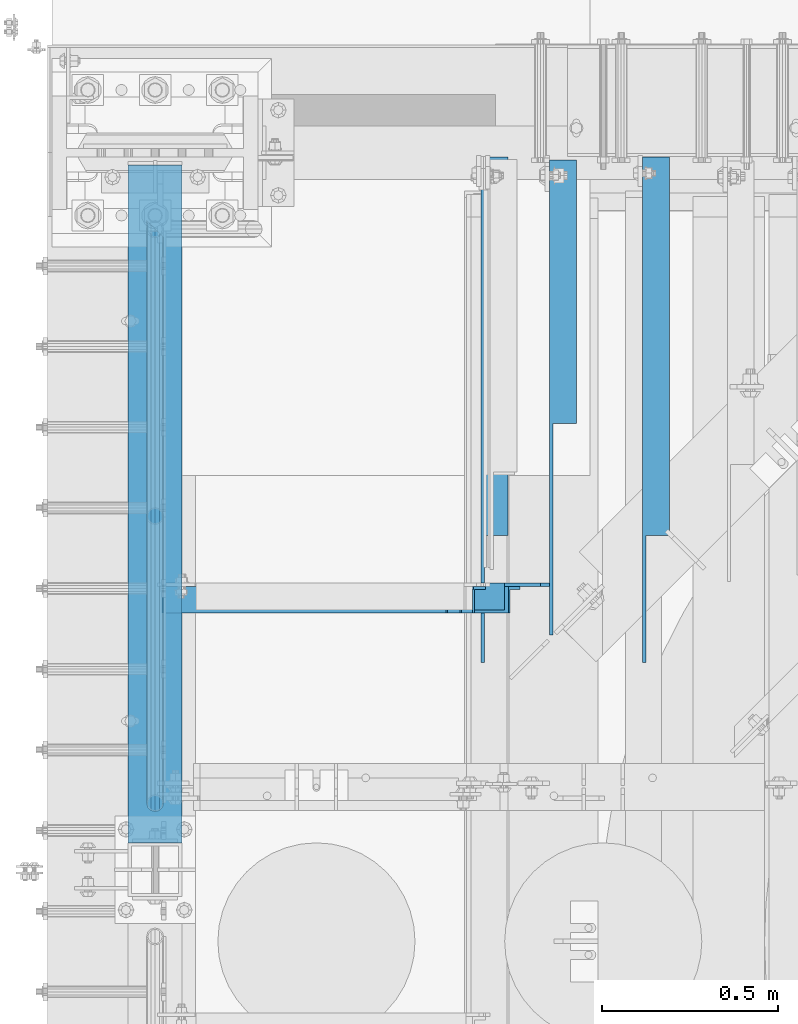
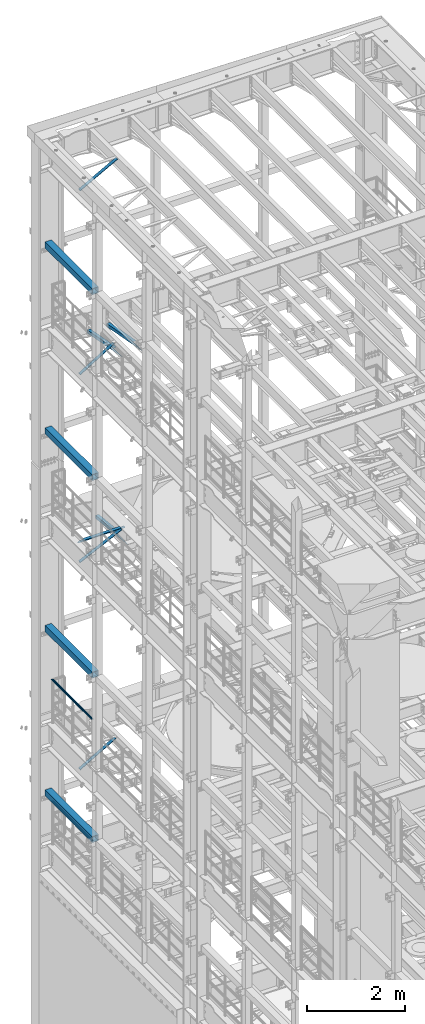
# One storey, part 1053 of 1876: 10 beams, 4 members, 14 elements without a shape of their own.
"""IFC2X3 building model written with IfcOpenShell, lengths in millimetres."""

from ifc_helpers import new_model, si_unit, frame, origin_with_axes, place, context, subcontext, project, spatial, faceted_brep, material, type_object, element, aggregate, save


model = new_model("IFC2X3")

# Units and contexts
model_context = context("Model", 3, precision=1e-05, world=origin_with_axes())
body_context = subcontext(model_context, "Body", "Model", "MODEL_VIEW")
ifc_project = project(units=[si_unit("LENGTHUNIT", "METRE", prefix="MILLI"), si_unit("AREAUNIT", "SQUARE_METRE"), si_unit("VOLUMEUNIT", "CUBIC_METRE"), si_unit("MASSUNIT", "GRAM", prefix="KILO"), si_unit("TIMEUNIT", "SECOND"), si_unit("PLANEANGLEUNIT", "RADIAN"), si_unit("SOLIDANGLEUNIT", "STERADIAN"), si_unit("THERMODYNAMICTEMPERATUREUNIT", "DEGREE_CELSIUS"), si_unit("LUMINOUSINTENSITYUNIT", "LUMEN")], contexts=[model_context])

# Site, building, storey
site_placement = place(None, origin_with_axes())
site = spatial("IfcSite", under=ifc_project, at=site_placement, CompositionType="ELEMENT")
building_placement = place(site_placement, origin_with_axes())
building = spatial("IfcBuilding", under=site, at=building_placement, Name="Undefined", CompositionType="ELEMENT")
storey_placement = place(building_placement, origin_with_axes())
storey = spatial("IfcBuildingStorey", under=building, at=storey_placement, Name="Undefined", CompositionType="ELEMENT", Elevation=0.0)

# Assembly, beam
assembly_1_placement = place(storey_placement, origin_with_axes())
assembly_1 = element("IfcElementAssembly", 1, at=assembly_1_placement, inside=storey, Name="RAIL", AssemblyPlace="NOTDEFINED", PredefinedType="RIGID_FRAME")
ifc_material_1 = material()
beam_type_1 = type_object("IfcBeamType", Name="PIPE1-1/2SCH40", PredefinedType="NOTDEFINED")
beam_1_placement = place(assembly_1_placement, frame((-2.72848410531878e-11, 11848.7825, 9229.725), z_axis=(0.0, 0.0, -1.0), x_axis=(0.0, 1.0, 0.0)))
beam_1 = element("IfcBeam", 2, at=beam_1_placement, type_object=beam_type_1, material=ifc_material_1, Name="RAIL", ObjectType="PIPE1-1/2SCH40", context=body_context, shape_type="Brep", body=[
    faceted_brep([(24.1300000000001, -20.4469999999999, 0.0), (34.3535000000002, -17.7076214311803, 10.2235000000001), (1668.63142143118, -17.7076214311804, 10.2235000000001), (1671.3708, -20.447, 0.0), (41.8376214311802, -10.2235000000001, 17.7076214311819), (1661.1473, -10.2235, 17.7076214311819), (44.5770000000002, 0.0, 20.4470000000001), (1650.9238, 0.0, 20.4470000000001), (41.8376214311802, 10.2235000000001, 17.7076214311819), (1640.7003, 10.2235, 17.7076214311819), (34.3535000000002, 17.7076214311803, 10.2235000000001), (1633.21617856882, 17.7076214311804, 10.2235000000001), (24.1300000000001, 20.4469999999999, 0.0), (1630.4768, 20.447, 0.0), (13.9065000000001, 17.7076214311803, -10.2235000000001), (1633.21617856882, 17.7076214311804, -10.2235000000001), (6.42237856882002, 10.2235000000001, -17.7076214311819), (1640.7003, 10.2235, -17.7076214311819), (3.68299999999999, 0.0, -20.4470000000001), (1650.9238, 0.0, -20.4470000000001), (6.42237856882002, -10.2235000000001, -17.7076214311819), (1661.1473, -10.2235, -17.7076214311819), (13.9065000000001, -17.7076214311803, -10.2235000000001), (1668.63142143118, -17.7076214311804, -10.2235000000001), (24.1299999999854, -24.1299999999992, 0.0), (12.0650000000064, -20.8971929933177, -12.0649999999987), (1671.82099299332, -20.8971929933185, -12.0649999999987), (1675.0538, -24.13, 0.0), (3.23280700668147, -12.0650000000001, -20.8971929933177), (1662.9888, -12.065, -20.8971929933177), (-1.45519152283669e-11, 0.0, -24.130000000001), (1650.9238, 0.0, -24.130000000001), (3.23280700668147, 12.0650000000001, -20.8971929933177), (1638.8588, 12.065, -20.8971929933177), (12.0650000000064, 20.8971929933177, -12.0649999999987), (1630.02660700668, 20.8971929933185, -12.0649999999987), (24.1300000000047, 24.1299999999992, 0.0), (1626.7938, 24.13, 0.0), (36.1949999999997, 20.8971929933184, 12.0649999999987), (1630.02660700668, 20.8971929933185, 12.0649999999987), (45.0271929933187, 12.0650000000001, 20.8971929933177), (1638.8588, 12.065, 20.8971929933177), (48.2600000000002, 0.0, 24.130000000001), (1650.9238, 0.0, 24.130000000001), (45.0271929933187, -12.0650000000001, 20.8971929933177), (1662.9888, -12.065, 20.8971929933177), (36.1949999999997, -20.8971929933184, 12.0649999999987), (1671.82099299332, -20.8971929933185, 12.0649999999987)], [[[0, 1, 2, 3]], [[1, 4, 5, 2]], [[4, 6, 7, 5]], [[6, 8, 9, 7]], [[8, 10, 11, 9]], [[10, 12, 13, 11]], [[12, 14, 15, 13]], [[14, 16, 17, 15]], [[16, 18, 19, 17]], [[18, 20, 21, 19]], [[20, 22, 23, 21]], [[22, 0, 3, 23]], [[24, 25, 26, 27]], [[25, 28, 29, 26]], [[28, 30, 31, 29]], [[30, 32, 33, 31]], [[32, 34, 35, 33]], [[34, 36, 37, 35]], [[36, 38, 39, 37]], [[38, 40, 41, 39]], [[40, 42, 43, 41]], [[42, 44, 45, 43]], [[44, 46, 47, 45]], [[46, 24, 27, 47]], [[29, 31, 33, 35, 37, 39, 41, 43, 45, 47, 27, 26], [5, 7, 9, 11, 13, 15, 17, 19, 21, 23, 3, 2]], [[46, 44, 42, 40, 38, 36, 34, 32, 30, 28, 25, 24], [22, 20, 18, 16, 14, 12, 10, 8, 6, 4, 1, 0]]]),
])
aggregate(assembly_1, [beam_1])

assembly_2_placement = place(storey_placement, origin_with_axes())
assembly_2 = element("IfcElementAssembly", 3, at=assembly_2_placement, inside=storey, Name="RAIL", AssemblyPlace="NOTDEFINED", PredefinedType="RIGID_FRAME")
beam_2_placement = place(assembly_2_placement, frame((-2.38742359215394e-11, 11848.7825, 6207.125), z_axis=(0.0, 0.0, -1.0), x_axis=(0.0, 1.0, 0.0)))
beam_2 = element("IfcBeam", 4, at=beam_2_placement, type_object=beam_type_1, material=ifc_material_1, Name="RAIL", ObjectType="PIPE1-1/2SCH40", context=body_context, shape_type="Brep", body=[
    faceted_brep([(24.1300000000001, -20.4469999999999, 0.0), (34.3535000000002, -17.7076214311803, 10.2235000000001), (1668.63142143118, -17.7076214311804, 10.2235000000001), (1671.3708, -20.447, 0.0), (41.8376214311802, -10.2235000000001, 17.7076214311819), (1661.1473, -10.2235, 17.7076214311819), (44.5770000000002, 0.0, 20.4470000000001), (1650.9238, 0.0, 20.4470000000001), (41.8376214311802, 10.2235000000001, 17.7076214311819), (1640.7003, 10.2235, 17.7076214311819), (34.3535000000002, 17.7076214311803, 10.2235000000001), (1633.21617856882, 17.7076214311804, 10.2235000000001), (24.1300000000001, 20.4469999999999, 0.0), (1630.4768, 20.447, 0.0), (13.9065000000001, 17.7076214311803, -10.2235000000001), (1633.21617856882, 17.7076214311804, -10.2235000000001), (6.42237856882002, 10.2235000000001, -17.7076214311819), (1640.7003, 10.2235, -17.7076214311819), (3.68299999999999, 0.0, -20.4470000000001), (1650.9238, 0.0, -20.4470000000001), (6.42237856882002, -10.2235000000001, -17.7076214311819), (1661.1473, -10.2235, -17.7076214311819), (13.9065000000001, -17.7076214311803, -10.2235000000001), (1668.63142143118, -17.7076214311804, -10.2235000000001), (24.1299999999854, -24.1299999999992, 0.0), (12.0650000000064, -20.8971929933177, -12.0649999999987), (1671.82099299332, -20.8971929933185, -12.0649999999987), (1675.0538, -24.13, 0.0), (3.23280700668147, -12.0650000000001, -20.8971929933177), (1662.9888, -12.065, -20.8971929933177), (-1.45519152283669e-11, 0.0, -24.130000000001), (1650.9238, 0.0, -24.130000000001), (3.23280700668147, 12.0650000000001, -20.8971929933177), (1638.8588, 12.065, -20.8971929933177), (12.0650000000064, 20.8971929933177, -12.0649999999987), (1630.02660700668, 20.8971929933185, -12.0649999999987), (24.1300000000047, 24.1299999999992, 0.0), (1626.7938, 24.13, 0.0), (36.1949999999997, 20.8971929933184, 12.0649999999987), (1630.02660700668, 20.8971929933185, 12.0649999999987), (45.0271929933187, 12.0650000000001, 20.8971929933177), (1638.8588, 12.065, 20.8971929933177), (48.2600000000002, 0.0, 24.130000000001), (1650.9238, 0.0, 24.130000000001), (45.0271929933187, -12.0650000000001, 20.8971929933177), (1662.9888, -12.065, 20.8971929933177), (36.1949999999997, -20.8971929933184, 12.0649999999987), (1671.82099299332, -20.8971929933185, 12.0649999999987)], [[[0, 1, 2, 3]], [[1, 4, 5, 2]], [[4, 6, 7, 5]], [[6, 8, 9, 7]], [[8, 10, 11, 9]], [[10, 12, 13, 11]], [[12, 14, 15, 13]], [[14, 16, 17, 15]], [[16, 18, 19, 17]], [[18, 20, 21, 19]], [[20, 22, 23, 21]], [[22, 0, 3, 23]], [[24, 25, 26, 27]], [[25, 28, 29, 26]], [[28, 30, 31, 29]], [[30, 32, 33, 31]], [[32, 34, 35, 33]], [[34, 36, 37, 35]], [[36, 38, 39, 37]], [[38, 40, 41, 39]], [[40, 42, 43, 41]], [[42, 44, 45, 43]], [[44, 46, 47, 45]], [[46, 24, 27, 47]], [[29, 31, 33, 35, 37, 39, 41, 43, 45, 47, 27, 26], [5, 7, 9, 11, 13, 15, 17, 19, 21, 23, 3, 2]], [[46, 44, 42, 40, 38, 36, 34, 32, 30, 28, 25, 24], [22, 20, 18, 16, 14, 12, 10, 8, 6, 4, 1, 0]]]),
])
aggregate(assembly_2, [beam_2])

assembly_3_placement = place(storey_placement, origin_with_axes())
assembly_3 = element("IfcElementAssembly", 5, at=assembly_3_placement, inside=storey, Name="BEAM", AssemblyPlace="NOTDEFINED", PredefinedType="RIGID_FRAME")
ifc_material_2 = material()
beam_type_2 = type_object("IfcBeamType", Name="HSS6X6X3/8", PredefinedType="NOTDEFINED")
beam_3_placement = place(assembly_3_placement, frame((0.0, 11684.0, 19958.05), z_axis=(-1.0, 0.0, 0.0), x_axis=(0.0, 1.0, 0.0)))
beam_3 = element("IfcBeam", 6, at=beam_3_placement, type_object=beam_type_2, material=ifc_material_2, Name="BEAM", ObjectType="HSS6X6X3/8", context=body_context, shape_type="Brep", body=[
    faceted_brep([(76.2000000000007, 66.6749999999993, -66.6750000000002), (76.2000000000007, -66.6749999999993, -66.6750000000002), (1997.86875, -66.6749999999993, -66.675), (1997.86875, 66.6749999999993, -66.675), (76.2000000000007, -66.6749999999993, 66.6750000000002), (1997.86875, -66.6749999999993, 66.675), (76.2000000000007, 66.6749999999993, 66.6750000000002), (1997.86875, 66.6749999999993, 66.675), (76.2000000000007, 76.2000000000007, -76.1999999999998), (76.2000000000007, 76.2000000000007, 76.1999999999998), (1997.86875, 76.2000000000007, 76.2), (1997.86875, 76.2000000000007, -76.2), (76.2000000000007, -76.2000000000007, 76.1999999999998), (1997.86875, -76.2000000000007, 76.2), (76.2000000000007, -76.2000000000007, -76.1999999999998), (1997.86875, -76.2000000000007, -76.2)], [[[0, 1, 2, 3]], [[1, 4, 5, 2]], [[4, 6, 7, 5]], [[6, 0, 3, 7]], [[8, 9, 10, 11]], [[9, 12, 13, 10]], [[12, 14, 15, 13]], [[14, 8, 11, 15]], [[13, 15, 11, 10], [5, 7, 3, 2]], [[14, 12, 9, 8], [6, 4, 1, 0]]]),
])
aggregate(assembly_3, [beam_3])

assembly_4_placement = place(storey_placement, origin_with_axes())
assembly_4 = element("IfcElementAssembly", 7, at=assembly_4_placement, inside=storey, Name="BEAM", AssemblyPlace="NOTDEFINED", PredefinedType="RIGID_FRAME")
beam_4_placement = place(assembly_4_placement, frame((0.0, 11684.0, 15335.25), z_axis=(-1.0, 0.0, 0.0), x_axis=(0.0, 1.0, 0.0)))
beam_4 = element("IfcBeam", 8, at=beam_4_placement, type_object=beam_type_2, material=ifc_material_2, Name="BEAM", ObjectType="HSS6X6X3/8", context=body_context, shape_type="Brep", body=[
    faceted_brep([(76.2000000000007, 66.6749999999993, -66.6750000000002), (76.2000000000007, -66.6749999999993, -66.6750000000002), (1997.86875, -66.6749999999993, -66.675), (1997.86875, 66.6749999999993, -66.675), (76.2000000000007, -66.6749999999993, 66.6750000000002), (1997.86875, -66.6749999999993, 66.675), (76.2000000000007, 66.6749999999993, 66.6750000000002), (1997.86875, 66.6749999999993, 66.675), (76.2000000000007, 76.2000000000007, -76.1999999999998), (76.2000000000007, 76.2000000000007, 76.1999999999998), (1997.86875, 76.2000000000007, 76.2), (1997.86875, 76.2000000000007, -76.2), (76.2000000000007, -76.2000000000007, 76.1999999999998), (1997.86875, -76.2000000000007, 76.2), (76.2000000000007, -76.2000000000007, -76.1999999999998), (1997.86875, -76.2000000000007, -76.2)], [[[0, 1, 2, 3]], [[1, 4, 5, 2]], [[4, 6, 7, 5]], [[6, 0, 3, 7]], [[8, 9, 10, 11]], [[9, 12, 13, 10]], [[12, 14, 15, 13]], [[14, 8, 11, 15]], [[13, 15, 11, 10], [5, 7, 3, 2]], [[14, 12, 9, 8], [6, 4, 1, 0]]]),
])
aggregate(assembly_4, [beam_4])

assembly_5_placement = place(storey_placement, origin_with_axes())
assembly_5 = element("IfcElementAssembly", 9, at=assembly_5_placement, inside=storey, Name="BEAM", AssemblyPlace="NOTDEFINED", PredefinedType="RIGID_FRAME")
beam_5_placement = place(assembly_5_placement, frame((0.0, 11684.0, 10420.35), z_axis=(-1.0, 0.0, 0.0), x_axis=(0.0, 1.0, 0.0)))
beam_5 = element("IfcBeam", 10, at=beam_5_placement, type_object=beam_type_2, material=ifc_material_2, Name="BEAM", ObjectType="HSS6X6X3/8", context=body_context, shape_type="Brep", body=[
    faceted_brep([(76.2000000000007, 66.6749999999993, -66.6750000000002), (76.2000000000007, -66.6749999999993, -66.6750000000002), (1997.86875, -66.6749999999993, -66.675), (1997.86875, 66.6749999999993, -66.675), (76.2000000000007, -66.6749999999993, 66.6750000000002), (1997.86875, -66.6749999999993, 66.675), (76.2000000000007, 66.6749999999993, 66.6750000000002), (1997.86875, 66.6749999999993, 66.675), (76.2000000000007, 76.2000000000007, -76.1999999999998), (76.2000000000007, 76.2000000000007, 76.1999999999998), (1997.86875, 76.2000000000007, 76.2), (1997.86875, 76.2000000000007, -76.2), (76.2000000000007, -76.2000000000007, 76.1999999999998), (1997.86875, -76.2000000000007, 76.2), (76.2000000000007, -76.2000000000007, -76.1999999999998), (1997.86875, -76.2000000000007, -76.2)], [[[0, 1, 2, 3]], [[1, 4, 5, 2]], [[4, 6, 7, 5]], [[6, 0, 3, 7]], [[8, 9, 10, 11]], [[9, 12, 13, 10]], [[12, 14, 15, 13]], [[14, 8, 11, 15]], [[13, 15, 11, 10], [5, 7, 3, 2]], [[14, 12, 9, 8], [6, 4, 1, 0]]]),
])
aggregate(assembly_5, [beam_5])

assembly_6_placement = place(storey_placement, origin_with_axes())
assembly_6 = element("IfcElementAssembly", 11, at=assembly_6_placement, inside=storey, Name="BEAM", AssemblyPlace="NOTDEFINED", PredefinedType="RIGID_FRAME")
beam_6_placement = place(assembly_6_placement, frame((0.0, 11684.0, 6330.95), z_axis=(-1.0, 0.0, 0.0), x_axis=(0.0, 1.0, 0.0)))
beam_6 = element("IfcBeam", 12, at=beam_6_placement, type_object=beam_type_2, material=ifc_material_2, Name="BEAM", ObjectType="HSS6X6X3/8", context=body_context, shape_type="Brep", body=[
    faceted_brep([(76.2000000000007, 66.6749999999993, -66.6750000000002), (76.2000000000007, -66.6749999999993, -66.6750000000002), (1997.86875, -66.6749999999993, -66.675), (1997.86875, 66.6749999999993, -66.675), (76.2000000000007, -66.6749999999993, 66.6750000000002), (1997.86875, -66.6749999999993, 66.675), (76.2000000000007, 66.6749999999993, 66.6750000000002), (1997.86875, 66.6749999999993, 66.675), (76.2000000000007, 76.2000000000007, -76.1999999999998), (76.2000000000007, 76.2000000000007, 76.1999999999998), (1997.86875, 76.2000000000007, 76.2), (1997.86875, 76.2000000000007, -76.2), (76.2000000000007, -76.2000000000007, 76.1999999999998), (1997.86875, -76.2000000000007, 76.2), (76.2000000000007, -76.2000000000007, -76.1999999999998), (1997.86875, -76.2000000000007, -76.2)], [[[0, 1, 2, 3]], [[1, 4, 5, 2]], [[4, 6, 7, 5]], [[6, 0, 3, 7]], [[8, 9, 10, 11]], [[9, 12, 13, 10]], [[12, 14, 15, 13]], [[14, 8, 11, 15]], [[13, 15, 11, 10], [5, 7, 3, 2]], [[14, 12, 9, 8], [6, 4, 1, 0]]]),
])
aggregate(assembly_6, [beam_6])

# Assembly, member
assembly_7_placement = place(storey_placement, origin_with_axes())
assembly_7 = element("IfcElementAssembly", 13, at=assembly_7_placement, inside=storey, AssemblyPlace="NOTDEFINED", PredefinedType="RIGID_FRAME")
ifc_material_3 = material(Name="STEEL/A36")
member_type = type_object("IfcMemberType", Name="L3X3X3/8", PredefinedType="NOTDEFINED")
member_1_placement = place(assembly_7_placement, frame((18.2754879686868, 12449.175, 22001.0692535961), z_axis=(0.0, -1.0, 0.0), x_axis=(0.877448093107104, 0.0, 0.479671600058526)))
member_1 = element("IfcMember", 14, at=member_1_placement, type_object=member_type, material=ifc_material_3, ObjectType="L3X3X3/8", context=body_context, shape_type="Brep", body=[
    faceted_brep([(22.6152978728696, 38.0999999999985, -38.0999999999999), (22.6152978728696, 38.0999999999985, 38.0999999999999), (1025.78606203808, 38.1000000013628, 38.0999999999999), (1025.78606203808, 38.1000000013628, -38.0999999999999), (22.6152978728605, 28.5750000000044, 38.0999999999999), (1025.78606203807, 28.5750000013722, 38.0999999999999), (22.6152978728605, 28.5750000000044, -28.5749999999998), (1025.78606203807, 28.5750000013722, -28.5749999999998), (22.6152978728023, -38.0999999999367, -28.5749999999998), (1025.78606203801, -38.0999999985652, -28.5749999999998), (22.6152978728023, -38.0999999999367, -38.0999999999999), (1025.78606203801, -38.0999999985652, -38.0999999999999)], [[[0, 1, 2, 3]], [[1, 4, 5, 2]], [[4, 6, 7, 5]], [[6, 8, 9, 7]], [[8, 10, 11, 9]], [[10, 0, 3, 11]], [[5, 7, 9, 11, 3, 2]], [[10, 8, 6, 4, 1, 0]]]),
])
aggregate(assembly_7, [member_1])

assembly_8_placement = place(storey_placement, origin_with_axes())
assembly_8 = element("IfcElementAssembly", 15, at=assembly_8_placement, inside=storey, AssemblyPlace="NOTDEFINED", PredefinedType="RIGID_FRAME")
member_2_placement = place(assembly_8_placement, frame((19.9928945830509, 12449.175, 17420.4891604457), z_axis=(0.0, -1.0, 0.0), x_axis=(0.851257688514323, 0.0, 0.524747889700618)))
member_2 = element("IfcMember", 16, at=member_2_placement, type_object=member_type, material=ifc_material_3, ObjectType="L3X3X3/8", context=body_context, shape_type="Brep", body=[
    faceted_brep([(25.5909295921792, 38.1000000000076, -38.1000000000004), (25.5909295921938, -38.1000000000404, -38.1000000000004), (25.5909295921938, -38.1000000000404, -28.5750000000007), (25.5909295921811, 28.5750000000025, -28.5750000000007), (25.5909295921811, 28.5750000000025, 38.1000000000004), (25.5909295921792, 38.1000000000076, 38.1000000000004), (968.184782924762, 28.5749999994605, 38.1000000000004), (968.18478292476, 38.0999999994638, 38.1000000000004), (968.18478292476, 38.0999999994638, -38.1000000000004), (968.184782924776, -38.1000000005788, -38.1000000000004), (968.184782924776, -38.1000000005788, -28.5750000000007), (968.184782924762, 28.5749999994605, -28.5750000000007)], [[[0, 1, 2, 3, 4, 5]], [[5, 4, 6, 7]], [[0, 5, 7, 8]], [[1, 0, 8, 9]], [[2, 1, 9, 10]], [[3, 2, 10, 11]], [[4, 3, 11, 6]], [[10, 9, 8, 7, 6, 11]]]),
])
aggregate(assembly_8, [member_2])

assembly_9_placement = place(storey_placement, origin_with_axes())
assembly_9 = element("IfcElementAssembly", 17, at=assembly_9_placement, inside=storey, AssemblyPlace="NOTDEFINED", PredefinedType="RIGID_FRAME")
member_3_placement = place(assembly_9_placement, frame((19.0458151523234, 12449.175, 7599.70204228665), z_axis=(0.0, -1.0, 0.0), x_axis=(0.866088809372667, 0.0, 0.499890162215098)))
member_3 = element("IfcMember", 18, at=member_3_placement, type_object=member_type, material=ifc_material_3, ObjectType="L3X3X3/8", context=body_context, shape_type="Brep", body=[
    faceted_brep([(997.169004128596, -38.0999999996484, -28.5750000000007), (997.169004128596, -38.0999999996484, -38.1000000000004), (997.169004128632, 38.1000000003687, -38.1000000000004), (997.169004128632, 38.1000000003687, 38.1000000000004), (997.169004128628, 28.5750000003663, 38.1000000000004), (997.169004128628, 28.5750000003663, -28.5750000000007), (22.911911287435, 28.5750000000162, 38.1000000000004), (22.911911287435, 28.5750000000162, -28.5750000000007), (22.9119112874018, -38.0999999999995, -28.5750000000007), (22.9119112874018, -38.0999999999995, -38.1000000000004), (22.9119112874396, 38.1000000000186, -38.1000000000004), (22.9119112874396, 38.1000000000186, 38.1000000000004)], [[[0, 1, 2, 3, 4, 5]], [[5, 4, 6, 7]], [[0, 5, 7, 8]], [[1, 0, 8, 9]], [[2, 1, 9, 10]], [[3, 2, 10, 11]], [[4, 3, 11, 6]], [[10, 9, 8, 7, 6, 11]]]),
])
aggregate(assembly_9, [member_3])

assembly_10_placement = place(storey_placement, origin_with_axes())
assembly_10 = element("IfcElementAssembly", 19, at=assembly_10_placement, inside=storey, Name="BRACE", AssemblyPlace="NOTDEFINED", PredefinedType="RIGID_FRAME")
member_4_placement = place(assembly_10_placement, frame((16.6315097138003, 12449.175, 12754.6216849212), z_axis=(0.0, -1.0, 0.0), x_axis=(0.899693308993905, 0.0, 0.436522564997043)))
member_4 = element("IfcMember", 20, at=member_4_placement, type_object=member_type, material=ifc_material_3, Name="BRACE", ObjectType="L3X3X3/8", context=body_context, shape_type="Brep", body=[
    faceted_brep([(22.0561271426632, 38.1000000000149, -38.1000000000004), (22.0561271426632, 38.1000000000149, 38.1000000000004), (1112.8290707969, 38.0999999992546, 38.1000000000004), (1112.8290707969, 38.0999999992546, -38.1000000000004), (22.056127142665, 28.5750000000062, 38.1000000000004), (1112.8290707969, 28.5749999992458, 38.1000000000004), (22.056127142665, 28.5750000000062, -28.5750000000007), (1112.8290707969, 28.5749999992458, -28.5750000000007), (22.0561271426868, -38.1000000000422, -28.5750000000007), (1112.82907079693, -38.1000000008062, -28.5750000000007), (22.0561271426868, -38.1000000000422, -38.1000000000004), (1112.82907079693, -38.1000000008062, -38.1000000000004)], [[[0, 1, 2, 3]], [[1, 4, 5, 2]], [[4, 6, 7, 5]], [[6, 8, 9, 7]], [[8, 10, 11, 9]], [[10, 0, 3, 11]], [[5, 7, 9, 11, 3, 2]], [[10, 8, 6, 4, 1, 0]]]),
])
aggregate(assembly_10, [member_4])

# Assembly, beam
assembly_11_placement = place(storey_placement, origin_with_axes())
assembly_11 = element("IfcElementAssembly", 21, at=assembly_11_placement, inside=storey, AssemblyPlace="NOTDEFINED", PredefinedType="RIGID_FRAME")
beam_type_3 = type_object("IfcBeamType", Name="L3X3X3/8", PredefinedType="NOTDEFINED")
beam_7_placement = place(assembly_11_placement, frame((1155.70000480063, 12303.2117193861, 12927.6473213718), z_axis=(1.0, 0.0, 0.0), x_axis=(0.0, 0.993801742077241, -0.11116698000864)))
beam_7 = element("IfcBeam", 22, at=beam_7_placement, type_object=beam_type_3, material=ifc_material_3, ObjectType="L3X3X3/8", context=body_context, shape_type="Brep", body=[
    faceted_brep([(1396.57162984495, -38.0999999996911, -28.575), (1396.57162984495, -38.0999999996911, -38.0999999999999), (1396.57162984495, 38.1000000003096, -38.0999999999999), (1396.57162984495, 38.1000000003096, 38.0999999999999), (1396.57162984495, 28.5750000003081, 38.0999999999999), (1396.57162984495, 28.5750000003081, -28.575), (731.882504487789, 38.1000000001623, 38.0999999999999), (646.731665699428, 28.5750000001426, 38.0999999999999), (646.731665699428, 28.5750000001426, -28.575), (50.6757941809065, -38.0999999999876, -28.575), (50.6757941809065, -38.0999999999876, -38.0999999999999), (731.882504487789, 38.1000000001623, -38.0999999999999)], [[[0, 1, 2, 3, 4, 5]], [[4, 3, 6, 7]], [[5, 4, 7, 8]], [[0, 5, 8, 9]], [[1, 0, 9, 10]], [[2, 1, 10, 11]], [[3, 2, 11, 6]], [[10, 9, 8, 7, 6, 11]]]),
])
aggregate(assembly_11, [beam_7])

assembly_12_placement = place(storey_placement, origin_with_axes())
assembly_12 = element("IfcElementAssembly", 23, at=assembly_12_placement, inside=storey, AssemblyPlace="NOTDEFINED", PredefinedType="RIGID_FRAME")
beam_8_placement = place(assembly_12_placement, frame((1419.225, 12478.7701585775, 17678.0584984364), z_axis=(1.0, 0.0, 0.0), x_axis=(0.0, 0.982729825630071, -0.185046182930343)))
beam_8 = element("IfcBeam", 24, at=beam_8_placement, type_object=beam_type_3, material=ifc_material_3, ObjectType="L3X3X3/8", context=body_context, shape_type="Brep", body=[
    faceted_brep([(200.493218531883, 38.099999999944, -38.1000000000004), (200.493218531883, 38.099999999944, 38.1000000000004), (1239.09835784596, 38.0999999993655, 38.1000000000004), (1239.09835784596, 38.0999999993655, -38.1000000000004), (149.908540475497, 28.5749999999571, 38.1000000000004), (1239.09863171315, 28.5749999993495, 38.1000000000004), (149.908540475497, 28.5749999999571, -28.5749999999998), (1239.09863171315, 28.5749999993495, -28.5749999999998), (-204.184205919202, -38.0999999999367, -28.5749999999998), (1239.10054878342, -38.1000000007407, -28.5749999999998), (-204.184205919202, -38.0999999999367, -38.1000000000004), (1239.10054878342, -38.1000000007407, -38.1000000000004)], [[[0, 1, 2, 3]], [[1, 4, 5, 2]], [[4, 6, 7, 5]], [[6, 8, 9, 7]], [[8, 10, 11, 9]], [[10, 0, 3, 11]], [[5, 7, 9, 11, 3, 2]], [[10, 8, 6, 4, 1, 0]]]),
])
aggregate(assembly_12, [beam_8])

assembly_13_placement = place(storey_placement, origin_with_axes())
assembly_13 = element("IfcElementAssembly", 25, at=assembly_13_placement, inside=storey, AssemblyPlace="NOTDEFINED", PredefinedType="RIGID_FRAME")
beam_9_placement = place(assembly_13_placement, frame((962.025, 12478.7701585775, 17678.0584984364), z_axis=(1.0, 0.0, 0.0), x_axis=(0.0, 0.982729825630071, -0.185046182930343)))
beam_9 = element("IfcBeam", 26, at=beam_9_placement, type_object=beam_type_3, material=ifc_material_3, ObjectType="L3X3X3/8", context=body_context, shape_type="Brep", body=[
    faceted_brep([(200.493218531883, 38.099999999944, -38.1000000000004), (200.493218531883, 38.099999999944, 38.1000000000004), (1239.09835784596, 38.0999999993655, 38.1000000000004), (1239.09835784596, 38.0999999993655, -38.1000000000004), (149.908540475497, 28.5749999999571, 38.1000000000004), (1239.09863171315, 28.5749999993495, 38.1000000000004), (149.908540475497, 28.5749999999571, -28.5749999999998), (1239.09863171315, 28.5749999993495, -28.5749999999998), (-204.184205919202, -38.0999999999367, -28.5749999999998), (1239.10054878342, -38.1000000007407, -28.5749999999998), (-204.184205919202, -38.0999999999367, -38.1000000000004), (1239.10054878342, -38.1000000007407, -38.1000000000004)], [[[0, 1, 2, 3]], [[1, 4, 5, 2]], [[4, 6, 7, 5]], [[6, 8, 9, 7]], [[8, 10, 11, 9]], [[10, 0, 3, 11]], [[5, 7, 9, 11, 3, 2]], [[10, 8, 6, 4, 1, 0]]]),
])
aggregate(assembly_13, [beam_9])

assembly_14_placement = place(storey_placement, origin_with_axes())
assembly_14 = element("IfcElementAssembly", 27, at=assembly_14_placement, inside=storey, Name="ANGLE", AssemblyPlace="NOTDEFINED", PredefinedType="RIGID_FRAME")
beam_10_placement = place(assembly_14_placement, frame((-6.16606574839512e-14, 12458.7, 13271.5), z_axis=(0.0, -1.0, 0.0), x_axis=(1.0, 0.0, 0.0)))
beam_10 = element("IfcBeam", 28, at=beam_10_placement, type_object=beam_type_3, material=ifc_material_3, Name="ANGLE", ObjectType="L3X3X3/8", context=body_context, shape_type="Brep", body=[
    faceted_brep([(115.886999817316, 38.0999999999985, 38.0999999999999), (115.886999817316, 28.5750000000007, 38.0999999999999), (990.600505801039, 28.5750000000007, 38.1000000000004), (990.60050580103, 38.1000000000004, 38.1000000000004), (115.88699895052, 28.5750000000007, -28.5749999999998), (990.600505067652, 28.5750000000007, -28.5750000000007), (1092.20000190903, 15.8750003814675, -28.5750000000007), (1092.20000180425, 15.8750003814675, -38.1000000000004), (990.600504962847, 15.8750003814675, -38.1000000000004), (990.600505067622, 15.8750003814675, -28.5750000000007), (990.600504962874, 38.1000000000004, -38.1000000000004), (115.886998826692, 38.0999999999985, -38.0999999999999), (115.88699882669, 12.699999237062, -38.0999999999999), (115.886998950515, 12.699999237062, -28.5749999999998), (38.8937432114558, 12.699999237062, -38.0999999999999), (38.8937433352807, 12.699999237062, -28.5749999999998), (7.14374321145577, -19.050000762938, -38.0999999999999), (7.14374333528067, -19.050000762938, -28.5749999999998), (7.1437499954859, -38.0999999999985, -38.0999999999999), (7.1437499954859, -38.0999999999985, -28.5749999999998), (1117.60000480063, -38.1000000000004, -28.5750000000007), (1117.60000152756, -9.52499923706273, -28.5750000000007), (1117.60000142278, -9.52499923706273, -38.1000000000004), (1117.60000480063, -38.1000000000004, -38.1000000000004)], [[[0, 1, 2, 3]], [[1, 4, 5, 2]], [[6, 7, 8, 9]], [[2, 5, 9, 8, 10, 3]], [[11, 0, 3, 10]], [[1, 0, 11, 12, 13, 4]], [[13, 12, 14, 15]], [[15, 14, 16, 17]], [[16, 18, 19, 17]], [[6, 9, 5, 4, 13, 15, 17, 19, 20, 21]], [[7, 6, 21, 22]], [[18, 16, 14, 12, 11, 10, 8, 7, 22, 23]], [[19, 18, 23, 20]], [[22, 21, 20, 23]]]),
])
aggregate(assembly_14, [beam_10])

save(model, "model.ifc")
